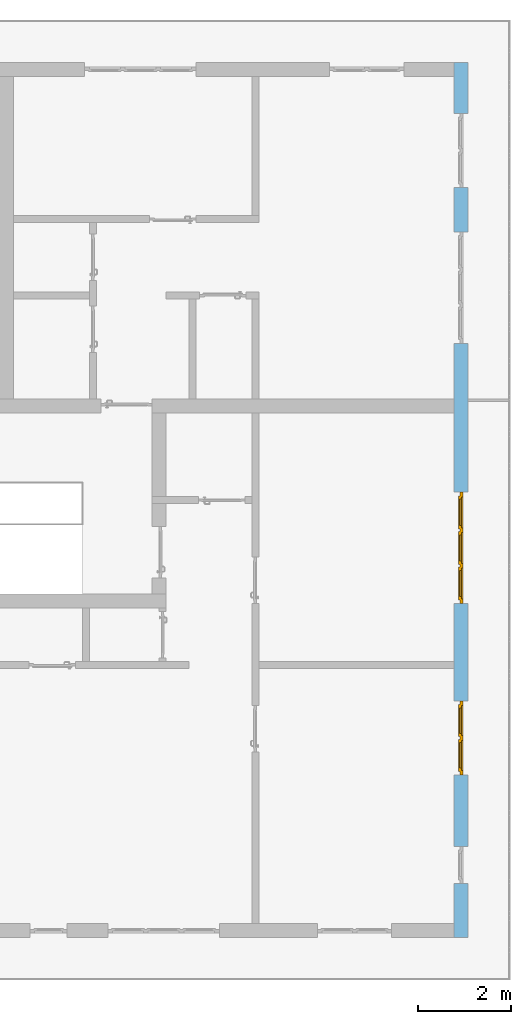
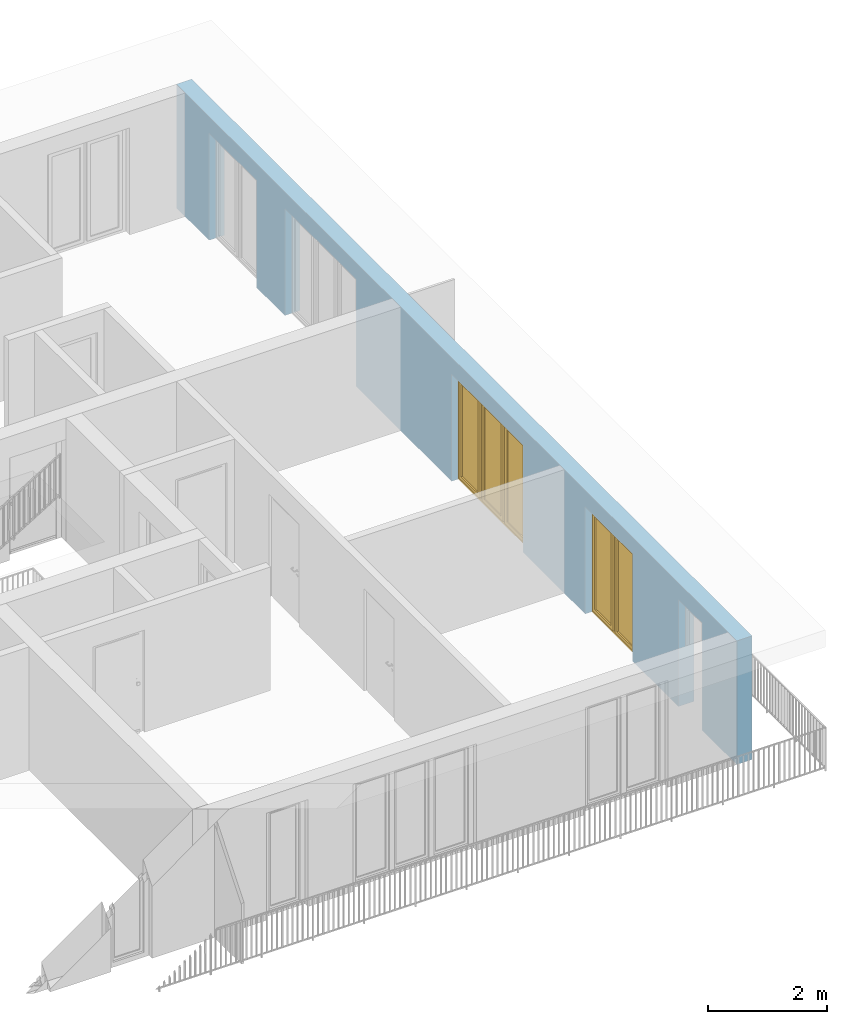
# One storey, part 21 of 54: 2 windows, 5 openings, plus 1 element that does not belong to this part.
"""IFC4 building model written with IfcOpenShell, lengths in metres."""

from ifc_helpers import new_model, entity, si_unit, converted_unit, derived_unit, direction, frame, origin_with_axes, place, context, subcontext, project, spatial, polygons, source, transform, mapped, material, type_object, element, fill, save


model = new_model("IFC4")

# Units and contexts
model_context = context("Model", 3, precision=1e-05, world=origin_with_axes(), true_north=direction((0.0, 1.0)))
body_context = subcontext(model_context, "Body", "Model", "MODEL_VIEW")
ifc_project = project(units=[si_unit("LENGTHUNIT", "METRE"), si_unit("AREAUNIT", "SQUARE_METRE"), si_unit("VOLUMEUNIT", "CUBIC_METRE"), converted_unit("PLANEANGLEUNIT", "DEGREE", entity("IfcPlaneAngleMeasure", 0.0174532925199), si_unit("PLANEANGLEUNIT", "RADIAN"), dimensions=[0, 0, 0, 0, 0, 0, 0]), converted_unit("TIMEUNIT", "Year", entity("IfcTimeMeasure", 31556926.0), si_unit("TIMEUNIT", "SECOND"), dimensions=[0, 0, 1, 0, 0, 0, 0]), si_unit("MASSUNIT", "GRAM", prefix="KILO"), si_unit("THERMODYNAMICTEMPERATUREUNIT", "DEGREE_CELSIUS"), si_unit("LUMINOUSINTENSITYUNIT", "LUMEN"), si_unit("ENERGYUNIT", "JOULE", prefix="MEGA"), derived_unit("THERMALCONDUCTANCEUNIT", [(si_unit("POWERUNIT", "WATT"), 1), (si_unit("LENGTHUNIT", "METRE"), -1), (si_unit("THERMODYNAMICTEMPERATUREUNIT", "KELVIN"), -1)]), derived_unit("SPECIFICHEATCAPACITYUNIT", [(si_unit("ENERGYUNIT", "JOULE"), 1), (si_unit("MASSUNIT", "GRAM", prefix="KILO"), -1), (si_unit("THERMODYNAMICTEMPERATUREUNIT", "KELVIN"), -1)]), derived_unit("MASSDENSITYUNIT", [(si_unit("MASSUNIT", "GRAM", prefix="KILO"), 1), (si_unit("VOLUMEUNIT", "CUBIC_METRE"), -1)])], contexts=[model_context])

# Site, building, storey
site_placement = place(None, origin_with_axes())
site = spatial("IfcSite", under=ifc_project, at=site_placement, CompositionType="ELEMENT")
building_placement = place(site_placement, origin_with_axes())
building = spatial("IfcBuilding", under=site, at=building_placement, CompositionType="ELEMENT")
storey_placement = place(building_placement, frame((0.0, 0.0, 6.29), z_axis=(0.0, 0.0, 1.0), x_axis=(1.0, 0.0, 0.0)))
storey = spatial("IfcBuildingStorey", under=building, at=storey_placement, Name="2. Geschoss", CompositionType="ELEMENT", Elevation=6.29)

# Wall, openings, windows
ifc_material = material()
wall_type = type_object("IfcWallType", Name="300", PredefinedType="NOTDEFINED")
wall_placement = place(storey_placement, frame((9.3378006196, -9.92881223104, 0.0), z_axis=(0.0, 0.0, 1.0), x_axis=(0.0, 1.0, 0.0)))
wall = element("IfcWall", 1, at=wall_placement, inside=storey, type_object=wall_type, material=ifc_material, Name="Wand-001", PredefinedType="NOTDEFINED", context=body_context, shape_type="Tessellation", body=[
    polygons([(1.16441876325, 0.1, 2.2), (1.96441876325, 0.1, 2.2), (1.96441876325, 0.0, 2.2), (1.16441876325, 0.0, 2.2), (1.16441876325, 0.3, 2.2), (1.96441876325, 0.3, 2.2), (1.96441876325, 0.1, 0.0), (1.96441876325, 0.0, 0.0), (18.85, 0.0, 2.54), (0.0, 0.0, 2.54), (0.0, 0.0, 0.0), (1.16441876325, 0.0, 0.0), (3.5, 0.0, 0.0), (3.5, 0.0, 2.2), (5.1, 0.0, 2.2), (5.1, 0.0, 0.0), (7.1921181063, 0.0, 0.0), (7.1921181063, 0.0, 2.2), (9.5921181063, 0.0, 2.2), (9.5921181063, 0.0, 0.0), (12.8, 0.0, 0.0), (12.8, 0.0, 2.2), (15.2, 0.0, 2.2), (15.2, 0.0, 0.0), (16.15, 0.0, 0.0), (16.15, 0.0, 2.2), (17.75, 0.0, 2.2), (17.75, 0.0, 0.0), (18.85, 0.0, 0.0), (1.16441876325, 0.1, 0.0), (1.16441876325, 0.3, 0.0), (0.0, 0.3, 0.0), (0.0, 0.3, 2.54), (18.85, 0.3, 2.54), (18.85, 0.3, 0.0), (17.75, 0.3, 0.0), (17.75, 0.3, 2.2), (16.15, 0.3, 2.2), (16.15, 0.3, 0.0), (15.2, 0.3, 0.0), (15.2, 0.3, 2.2), (12.8, 0.3, 2.2), (12.8, 0.3, 0.0), (9.5921181063, 0.3, 0.0), (9.5921181063, 0.3, 2.2), (7.1921181063, 0.3, 2.2), (7.1921181063, 0.3, 0.0), (5.1, 0.3, 0.0), (5.1, 0.3, 2.2), (3.5, 0.3, 2.2), (3.5, 0.3, 0.0), (1.96441876325, 0.3, 0.0), (3.5, 0.1, 0.0), (3.5, 0.1, 2.2), (5.1, 0.1, 2.2), (5.1, 0.1, 0.0), (7.1921181063, 0.1, 0.0), (7.1921181063, 0.1, 2.2), (9.5921181063, 0.1, 2.2), (9.5921181063, 0.1, 0.0), (12.8, 0.1, 0.0), (12.8, 0.1, 2.2), (15.2, 0.1, 2.2), (15.2, 0.1, 0.0), (16.15, 0.1, 0.0), (16.15, 0.1, 2.2), (17.75, 0.1, 2.2), (17.75, 0.1, 0.0)], [[[1, 2, 3, 4]], [[2, 1, 5, 6]], [[2, 7, 8, 3]], [[9, 10, 11, 12, 4, 3, 8, 13, 14, 15, 16, 17, 18, 19, 20, 21, 22, 23, 24, 25, 26, 27, 28, 29]], [[30, 1, 4, 12]], [[1, 30, 31, 5]], [[5, 31, 32, 33, 34, 35, 36, 37, 38, 39, 40, 41, 42, 43, 44, 45, 46, 47, 48, 49, 50, 51, 52, 6]], [[7, 2, 6, 52]], [[7, 52, 51, 53, 13, 8]], [[9, 34, 33, 10]], [[33, 32, 11, 10]], [[31, 30, 12, 11, 32]], [[14, 13, 53, 54]], [[15, 14, 54, 55]], [[16, 15, 55, 56]], [[56, 48, 47, 57, 17, 16]], [[57, 58, 18, 17]], [[58, 59, 19, 18]], [[59, 60, 20, 19]], [[60, 44, 43, 61, 21, 20]], [[22, 21, 61, 62]], [[23, 22, 62, 63]], [[24, 23, 63, 64]], [[64, 40, 39, 65, 25, 24]], [[65, 66, 26, 25]], [[66, 67, 27, 26]], [[67, 68, 28, 27]], [[36, 35, 29, 28, 68]], [[9, 29, 35, 34]], [[68, 67, 37, 36]], [[67, 66, 38, 37]], [[66, 65, 39, 38]], [[41, 40, 64, 63]], [[42, 41, 63, 62]], [[43, 42, 62, 61]], [[60, 59, 45, 44]], [[59, 58, 46, 45]], [[58, 57, 47, 46]], [[49, 48, 56, 55]], [[50, 49, 55, 54]], [[51, 50, 54, 53]]], closed=True),
])
opening_1_placement = place(wall_placement, frame((16.95, 0.0, 0.0), z_axis=(0.0, 0.0, 1.0), x_axis=(1.0, 0.0, 0.0)))
element("IfcOpeningElement", 2, at=opening_1_placement, cuts=wall, Name="Fenster-001", context=body_context, identifier="Reference", shape_type="Tessellation", body=[
    polygons([(0.8, 0.1, 0.0), (0.8, 0.1, 2.2), (0.8, -0.000999999999999, 2.2), (0.8, -0.000999999999999, 0.0), (0.8, 0.301, 0.0), (0.8, 0.301, 2.2), (-0.8, 0.1, 2.2), (-0.8, -0.000999999999999, 2.2), (-0.8, 0.301, 2.2), (-0.8, -0.000999999999999, 0.0), (-0.8, 0.1, 0.0), (-0.8, 0.301, 0.0)], [[[1, 2, 3, 4]], [[2, 1, 5, 6]], [[7, 8, 3, 2, 6, 9]], [[8, 10, 4, 3]], [[1, 4, 10, 11, 12, 5]], [[6, 5, 12, 9]], [[7, 11, 10, 8]], [[11, 7, 9, 12]]], closed=True),
])
opening_2_placement = place(wall_placement, frame((14.0, 0.0, 0.0), z_axis=(0.0, 0.0, 1.0), x_axis=(1.0, 0.0, 0.0)))
element("IfcOpeningElement", 3, at=opening_2_placement, cuts=wall, Name="Fenster-002", context=body_context, identifier="Reference", shape_type="Tessellation", body=[
    polygons([(1.2, 0.1, 0.0), (1.2, 0.1, 2.2), (1.2, -0.000999999999999, 2.2), (1.2, -0.000999999999999, 0.0), (1.2, 0.301, 0.0), (1.2, 0.301, 2.2), (-1.2, 0.1, 2.2), (-1.2, -0.000999999999999, 2.2), (-1.2, 0.301, 2.2), (-1.2, -0.000999999999999, 0.0), (-1.2, 0.1, 0.0), (-1.2, 0.301, 0.0)], [[[1, 2, 3, 4]], [[2, 1, 5, 6]], [[7, 8, 3, 2, 6, 9]], [[8, 10, 4, 3]], [[1, 4, 10, 11, 12, 5]], [[6, 5, 12, 9]], [[7, 11, 10, 8]], [[11, 7, 9, 12]]], closed=True),
])
opening_3_placement = place(wall_placement, frame((8.3921181063, 0.0, 0.0), z_axis=(0.0, 0.0, 1.0), x_axis=(1.0, 0.0, 0.0)))
opening_3 = element("IfcOpeningElement", 4, at=opening_3_placement, cuts=wall, Name="Fenster-002", context=body_context, identifier="Reference", shape_type="Tessellation", body=[
    polygons([(1.2, 0.1, 0.0), (1.2, 0.1, 2.2), (1.2, -0.000999999999999, 2.2), (1.2, -0.000999999999999, 0.0), (1.2, 0.301, 0.0), (1.2, 0.301, 2.2), (-1.2, 0.1, 2.2), (-1.2, -0.000999999999999, 2.2), (-1.2, 0.301, 2.2), (-1.2, -0.000999999999999, 0.0), (-1.2, 0.1, 0.0), (-1.2, 0.301, 0.0)], [[[1, 2, 3, 4]], [[2, 1, 5, 6]], [[7, 8, 3, 2, 6, 9]], [[8, 10, 4, 3]], [[1, 4, 10, 11, 12, 5]], [[6, 5, 12, 9]], [[7, 11, 10, 8]], [[11, 7, 9, 12]]], closed=True),
])
opening_4_placement = place(wall_placement, frame((4.3, 0.0, 0.0), z_axis=(0.0, 0.0, 1.0), x_axis=(1.0, 0.0, 0.0)))
opening_4 = element("IfcOpeningElement", 5, at=opening_4_placement, cuts=wall, Name="Fenster-001", context=body_context, identifier="Reference", shape_type="Tessellation", body=[
    polygons([(0.8, 0.1, 0.0), (0.8, 0.1, 2.2), (0.8, -0.000999999999999, 2.2), (0.8, -0.000999999999999, 0.0), (0.8, 0.301, 0.0), (0.8, 0.301, 2.2), (-0.8, 0.1, 2.2), (-0.8, -0.000999999999999, 2.2), (-0.8, 0.301, 2.2), (-0.8, -0.000999999999999, 0.0), (-0.8, 0.1, 0.0), (-0.8, 0.301, 0.0)], [[[1, 2, 3, 4]], [[2, 1, 5, 6]], [[7, 8, 3, 2, 6, 9]], [[8, 10, 4, 3]], [[1, 4, 10, 11, 12, 5]], [[6, 5, 12, 9]], [[7, 11, 10, 8]], [[11, 7, 9, 12]]], closed=True),
])
opening_5_placement = place(wall_placement, frame((1.56441876325, 0.0, 0.0), z_axis=(0.0, 0.0, 1.0), x_axis=(1.0, 0.0, 0.0)))
element("IfcOpeningElement", 6, at=opening_5_placement, cuts=wall, Name="Fenster-003", context=body_context, identifier="Reference", shape_type="Tessellation", body=[
    polygons([(0.4, 0.1, 0.0), (0.4, 0.1, 2.2), (0.4, -0.000999999999999, 2.2), (0.4, -0.000999999999999, 0.0), (0.4, 0.301, 0.0), (0.4, 0.301, 2.2), (-0.4, 0.1, 2.2), (-0.4, -0.000999999999999, 2.2), (-0.4, 0.301, 2.2), (-0.4, -0.000999999999999, 0.0), (-0.4, 0.1, 0.0), (-0.4, 0.301, 0.0)], [[[1, 2, 3, 4]], [[2, 1, 5, 6]], [[7, 8, 3, 2, 6, 9]], [[8, 10, 4, 3]], [[1, 4, 10, 11, 12, 5]], [[6, 5, 12, 9]], [[7, 11, 10, 8]], [[11, 7, 9, 12]]], closed=True),
])
window_type_1 = type_object("IfcWindowType", Name="3-1+1+1 26", PartitioningType="TRIPLE_PANEL_VERTICAL", PredefinedType="WINDOW")
shared_shape_1 = source(origin_with_axes(), body_context, "Body", "Tessellation", [
    polygons([(-1.2, -0.07, 0.0), (-1.2, 0.0, 0.0), (-1.1, 0.0, 0.1), (-1.1, -0.07, 0.1), (-1.2, -0.07, 2.2), (-1.2, 0.0, 2.2), (-1.1, 0.0, 2.1), (-1.1, -0.07, 2.1)], [[[1, 2, 3, 4]], [[5, 6, 2, 1]], [[2, 6, 7, 3]], [[4, 3, 7, 8]], [[1, 4, 8, 5]], [[8, 7, 6, 5]]], closed=True),
    polygons([(1.2, -0.07, 0.0), (1.2, 0.0, 0.0), (1.2, 0.0, 2.2), (1.2, -0.07, 2.2), (1.1, -0.07, 0.1), (1.1, 0.0, 0.1), (1.1, 0.0, 2.1), (1.1, -0.07, 2.1)], [[[1, 2, 3, 4]], [[5, 6, 2, 1]], [[2, 6, 7, 3]], [[4, 3, 7, 8]], [[1, 4, 8, 5]], [[8, 7, 6, 5]]], closed=True),
    polygons([(-1.2, -0.07, 0.0), (-1.2, 0.0, 0.0), (1.2, 0.0, 0.0), (1.2, -0.07, 0.0), (-1.1, -0.07, 0.1), (-1.1, 0.0, 0.1), (-0.433333333333, 0.0, 0.1), (-0.333333333333, 0.0, 0.1), (0.333333333333, 0.0, 0.1), (0.433333333333, 0.0, 0.1), (1.1, 0.0, 0.1), (1.1, -0.07, 0.1), (0.433333333333, -0.07, 0.1), (0.333333333333, -0.07, 0.1), (-0.333333333333, -0.07, 0.1), (-0.433333333333, -0.07, 0.1)], [[[1, 2, 3, 4]], [[5, 6, 2, 1]], [[2, 6, 7, 8, 9, 10, 11, 3]], [[4, 3, 11, 12]], [[1, 4, 12, 13, 14, 15, 16, 5]], [[16, 7, 6, 5]], [[15, 8, 7, 16]], [[14, 9, 8, 15]], [[13, 10, 9, 14]], [[12, 11, 10, 13]]], closed=True),
    polygons([(-1.2, -0.07, 2.2), (-1.2, 0.0, 2.2), (-1.1, 0.0, 2.1), (-1.1, -0.07, 2.1), (1.2, -0.07, 2.2), (1.2, 0.0, 2.2), (1.1, 0.0, 2.1), (0.433333333333, 0.0, 2.1), (0.333333333333, 0.0, 2.1), (-0.333333333333, 0.0, 2.1), (-0.433333333333, 0.0, 2.1), (-0.433333333333, -0.07, 2.1), (-0.333333333333, -0.07, 2.1), (0.333333333333, -0.07, 2.1), (0.433333333333, -0.07, 2.1), (1.1, -0.07, 2.1)], [[[1, 2, 3, 4]], [[5, 6, 2, 1]], [[2, 6, 7, 8, 9, 10, 11, 3]], [[4, 3, 11, 12]], [[1, 4, 12, 13, 14, 15, 16, 5]], [[16, 7, 6, 5]], [[15, 8, 7, 16]], [[14, 9, 8, 15]], [[13, 10, 9, 14]], [[12, 11, 10, 13]]], closed=True),
    polygons([(0.333333333333, -0.07, 0.1), (0.333333333333, 0.0, 0.1), (0.433333333333, 0.0, 0.1), (0.433333333333, -0.07, 0.1), (0.333333333333, -0.07, 2.1), (0.333333333333, 0.0, 2.1), (0.433333333333, 0.0, 2.1), (0.433333333333, -0.07, 2.1)], [[[1, 2, 3, 4]], [[5, 6, 2, 1]], [[2, 6, 7, 3]], [[4, 3, 7, 8]], [[1, 4, 8, 5]], [[8, 7, 6, 5]]], closed=True),
    polygons([(-0.433333333333, -0.07, 0.1), (-0.433333333333, 0.0, 0.1), (-0.333333333333, 0.0, 0.1), (-0.333333333333, -0.07, 0.1), (-0.433333333333, -0.07, 2.1), (-0.433333333333, 0.0, 2.1), (-0.333333333333, 0.0, 2.1), (-0.333333333333, -0.07, 2.1)], [[[1, 2, 3, 4]], [[5, 6, 2, 1]], [[2, 6, 7, 3]], [[4, 3, 7, 8]], [[1, 4, 8, 5]], [[8, 7, 6, 5]]], closed=True),
    polygons([(-1.12, 0.0, 0.08), (-1.12, 0.03, 0.08), (-1.05, 0.03, 0.15), (-1.05, 0.0, 0.15), (-1.12, 0.0, 2.12), (-1.12, 0.03, 2.12), (-1.05, 0.03, 2.05), (-1.05, 0.0, 2.05)], [[[1, 2, 3, 4]], [[5, 6, 2, 1]], [[2, 6, 7, 3]], [[4, 3, 7, 8]], [[1, 4, 8, 5]], [[8, 7, 6, 5]]], closed=True),
    polygons([(-0.413333333333, 0.0, 0.08), (-0.483333333333, 0.0, 0.15), (-0.483333333333, 0.03, 0.15), (-0.413333333333, 0.03, 0.08), (-0.413333333333, 0.0, 2.12), (-0.483333333333, 0.0, 2.05), (-0.483333333333, 0.03, 2.05), (-0.413333333333, 0.03, 2.12)], [[[1, 2, 3, 4]], [[1, 5, 6, 2]], [[2, 6, 7, 3]], [[4, 3, 7, 8]], [[5, 1, 4, 8]], [[6, 5, 8, 7]]], closed=True),
    polygons([(-1.12, 0.0, 0.08), (-1.12, 0.03, 0.08), (-0.413333333333, 0.03, 0.08), (-0.413333333333, 0.0, 0.08), (-1.05, 0.0, 0.15), (-1.05, 0.03, 0.15), (-0.483333333333, 0.03, 0.15), (-0.483333333333, 0.0, 0.15)], [[[1, 2, 3, 4]], [[5, 6, 2, 1]], [[2, 6, 7, 3]], [[4, 3, 7, 8]], [[1, 4, 8, 5]], [[8, 7, 6, 5]]], closed=True),
    polygons([(-1.12, 0.0, 2.12), (-0.413333333333, 0.0, 2.12), (-0.413333333333, 0.03, 2.12), (-1.12, 0.03, 2.12), (-1.05, 0.0, 2.05), (-0.483333333333, 0.0, 2.05), (-0.483333333333, 0.03, 2.05), (-1.05, 0.03, 2.05)], [[[1, 2, 3, 4]], [[1, 5, 6, 2]], [[2, 6, 7, 3]], [[4, 3, 7, 8]], [[5, 1, 4, 8]], [[6, 5, 8, 7]]], closed=True),
    polygons([(-1.1, -0.03, 0.1), (-1.1, 0.0, 0.1), (-1.05, 0.0, 0.15), (-1.05, -0.03, 0.15), (-1.1, -0.03, 2.1), (-1.1, 0.0, 2.1), (-1.05, 0.0, 2.05), (-1.05, -0.03, 2.05)], [[[1, 2, 3, 4]], [[5, 6, 2, 1]], [[2, 6, 7, 3]], [[4, 3, 7, 8]], [[1, 4, 8, 5]], [[8, 7, 6, 5]]], closed=True),
    polygons([(-0.433333333333, -0.03, 0.1), (-0.483333333333, -0.03, 0.15), (-0.483333333333, 0.0, 0.15), (-0.433333333333, 0.0, 0.1), (-0.433333333333, -0.03, 2.1), (-0.483333333333, -0.03, 2.05), (-0.483333333333, 0.0, 2.05), (-0.433333333333, 0.0, 2.1)], [[[1, 2, 3, 4]], [[1, 5, 6, 2]], [[2, 6, 7, 3]], [[4, 3, 7, 8]], [[5, 1, 4, 8]], [[6, 5, 8, 7]]], closed=True),
    polygons([(-1.1, -0.03, 0.1), (-1.1, 0.0, 0.1), (-0.433333333333, 0.0, 0.1), (-0.433333333333, -0.03, 0.1), (-1.05, -0.03, 0.15), (-1.05, 0.0, 0.15), (-0.483333333333, 0.0, 0.15), (-0.483333333333, -0.03, 0.15)], [[[1, 2, 3, 4]], [[5, 6, 2, 1]], [[2, 6, 7, 3]], [[4, 3, 7, 8]], [[1, 4, 8, 5]], [[8, 7, 6, 5]]], closed=True),
    polygons([(-1.1, -0.03, 2.1), (-0.433333333333, -0.03, 2.1), (-0.433333333333, 0.0, 2.1), (-1.1, 0.0, 2.1), (-1.05, -0.03, 2.05), (-0.483333333333, -0.03, 2.05), (-0.483333333333, 0.0, 2.05), (-1.05, 0.0, 2.05)], [[[1, 2, 3, 4]], [[1, 5, 6, 2]], [[2, 6, 7, 3]], [[4, 3, 7, 8]], [[5, 1, 4, 8]], [[6, 5, 8, 7]]], closed=True),
    polygons([(-1.05, -0.005, 0.15), (-1.05, 0.005, 0.15), (-0.483333333333, 0.005, 0.15), (-0.483333333333, -0.005, 0.15), (-1.05, -0.005, 2.05), (-1.05, 0.005, 2.05), (-0.483333333333, 0.005, 2.05), (-0.483333333333, -0.005, 2.05)], [[[1, 2, 3, 4]], [[5, 6, 2, 1]], [[2, 6, 7, 3]], [[4, 3, 7, 8]], [[1, 4, 8, 5]], [[8, 7, 6, 5]]], closed=True),
    polygons([(-0.353333333333, 0.0, 0.08), (-0.353333333333, 0.03, 0.08), (-0.283333333333, 0.03, 0.15), (-0.283333333333, 0.0, 0.15), (-0.353333333333, 0.0, 2.12), (-0.353333333333, 0.03, 2.12), (-0.283333333333, 0.03, 2.05), (-0.283333333333, 0.0, 2.05)], [[[1, 2, 3, 4]], [[5, 6, 2, 1]], [[2, 6, 7, 3]], [[4, 3, 7, 8]], [[1, 4, 8, 5]], [[8, 7, 6, 5]]], closed=True),
    polygons([(0.353333333333, 0.0, 0.08), (0.283333333333, 0.0, 0.15), (0.283333333333, 0.03, 0.15), (0.353333333333, 0.03, 0.08), (0.353333333333, 0.0, 2.12), (0.283333333333, 0.0, 2.05), (0.283333333333, 0.03, 2.05), (0.353333333333, 0.03, 2.12)], [[[1, 2, 3, 4]], [[1, 5, 6, 2]], [[2, 6, 7, 3]], [[4, 3, 7, 8]], [[5, 1, 4, 8]], [[6, 5, 8, 7]]], closed=True),
    polygons([(-0.353333333333, 0.0, 0.08), (-0.353333333333, 0.03, 0.08), (0.353333333333, 0.03, 0.08), (0.353333333333, 0.0, 0.08), (-0.283333333333, 0.0, 0.15), (-0.283333333333, 0.03, 0.15), (0.283333333333, 0.03, 0.15), (0.283333333333, 0.0, 0.15)], [[[1, 2, 3, 4]], [[5, 6, 2, 1]], [[2, 6, 7, 3]], [[4, 3, 7, 8]], [[1, 4, 8, 5]], [[8, 7, 6, 5]]], closed=True),
    polygons([(-0.353333333333, 0.0, 2.12), (0.353333333333, 0.0, 2.12), (0.353333333333, 0.03, 2.12), (-0.353333333333, 0.03, 2.12), (-0.283333333333, 0.0, 2.05), (0.283333333333, 0.0, 2.05), (0.283333333333, 0.03, 2.05), (-0.283333333333, 0.03, 2.05)], [[[1, 2, 3, 4]], [[1, 5, 6, 2]], [[2, 6, 7, 3]], [[4, 3, 7, 8]], [[5, 1, 4, 8]], [[6, 5, 8, 7]]], closed=True),
    polygons([(-0.333333333333, -0.03, 0.1), (-0.333333333333, 0.0, 0.1), (-0.283333333333, 0.0, 0.15), (-0.283333333333, -0.03, 0.15), (-0.333333333333, -0.03, 2.1), (-0.333333333333, 0.0, 2.1), (-0.283333333333, 0.0, 2.05), (-0.283333333333, -0.03, 2.05)], [[[1, 2, 3, 4]], [[5, 6, 2, 1]], [[2, 6, 7, 3]], [[4, 3, 7, 8]], [[1, 4, 8, 5]], [[8, 7, 6, 5]]], closed=True),
    polygons([(0.333333333333, -0.03, 0.1), (0.283333333333, -0.03, 0.15), (0.283333333333, 0.0, 0.15), (0.333333333333, 0.0, 0.1), (0.333333333333, -0.03, 2.1), (0.283333333333, -0.03, 2.05), (0.283333333333, 0.0, 2.05), (0.333333333333, 0.0, 2.1)], [[[1, 2, 3, 4]], [[1, 5, 6, 2]], [[2, 6, 7, 3]], [[4, 3, 7, 8]], [[5, 1, 4, 8]], [[6, 5, 8, 7]]], closed=True),
    polygons([(-0.333333333333, -0.03, 0.1), (-0.333333333333, 0.0, 0.1), (0.333333333333, 0.0, 0.1), (0.333333333333, -0.03, 0.1), (-0.283333333333, -0.03, 0.15), (-0.283333333333, 0.0, 0.15), (0.283333333333, 0.0, 0.15), (0.283333333333, -0.03, 0.15)], [[[1, 2, 3, 4]], [[5, 6, 2, 1]], [[2, 6, 7, 3]], [[4, 3, 7, 8]], [[1, 4, 8, 5]], [[8, 7, 6, 5]]], closed=True),
    polygons([(-0.333333333333, -0.03, 2.1), (0.333333333333, -0.03, 2.1), (0.333333333333, 0.0, 2.1), (-0.333333333333, 0.0, 2.1), (-0.283333333333, -0.03, 2.05), (0.283333333333, -0.03, 2.05), (0.283333333333, 0.0, 2.05), (-0.283333333333, 0.0, 2.05)], [[[1, 2, 3, 4]], [[1, 5, 6, 2]], [[2, 6, 7, 3]], [[4, 3, 7, 8]], [[5, 1, 4, 8]], [[6, 5, 8, 7]]], closed=True),
    polygons([(-0.283333333333, -0.005, 0.15), (-0.283333333333, 0.005, 0.15), (0.283333333333, 0.005, 0.15), (0.283333333333, -0.005, 0.15), (-0.283333333333, -0.005, 2.05), (-0.283333333333, 0.005, 2.05), (0.283333333333, 0.005, 2.05), (0.283333333333, -0.005, 2.05)], [[[1, 2, 3, 4]], [[5, 6, 2, 1]], [[2, 6, 7, 3]], [[4, 3, 7, 8]], [[1, 4, 8, 5]], [[8, 7, 6, 5]]], closed=True),
    polygons([(0.413333333333, 0.0, 0.08), (0.413333333333, 0.03, 0.08), (0.483333333333, 0.03, 0.15), (0.483333333333, 0.0, 0.15), (0.413333333333, 0.0, 2.12), (0.413333333333, 0.03, 2.12), (0.483333333333, 0.03, 2.05), (0.483333333333, 0.0, 2.05)], [[[1, 2, 3, 4]], [[5, 6, 2, 1]], [[2, 6, 7, 3]], [[4, 3, 7, 8]], [[1, 4, 8, 5]], [[8, 7, 6, 5]]], closed=True),
    polygons([(1.12, 0.0, 0.08), (1.05, 0.0, 0.15), (1.05, 0.03, 0.15), (1.12, 0.03, 0.08), (1.12, 0.0, 2.12), (1.05, 0.0, 2.05), (1.05, 0.03, 2.05), (1.12, 0.03, 2.12)], [[[1, 2, 3, 4]], [[1, 5, 6, 2]], [[2, 6, 7, 3]], [[4, 3, 7, 8]], [[5, 1, 4, 8]], [[6, 5, 8, 7]]], closed=True),
    polygons([(0.413333333333, 0.0, 0.08), (0.413333333333, 0.03, 0.08), (1.12, 0.03, 0.08), (1.12, 0.0, 0.08), (0.483333333333, 0.0, 0.15), (0.483333333333, 0.03, 0.15), (1.05, 0.03, 0.15), (1.05, 0.0, 0.15)], [[[1, 2, 3, 4]], [[5, 6, 2, 1]], [[2, 6, 7, 3]], [[4, 3, 7, 8]], [[1, 4, 8, 5]], [[8, 7, 6, 5]]], closed=True),
    polygons([(0.413333333333, 0.0, 2.12), (1.12, 0.0, 2.12), (1.12, 0.03, 2.12), (0.413333333333, 0.03, 2.12), (0.483333333333, 0.0, 2.05), (1.05, 0.0, 2.05), (1.05, 0.03, 2.05), (0.483333333333, 0.03, 2.05)], [[[1, 2, 3, 4]], [[1, 5, 6, 2]], [[2, 6, 7, 3]], [[4, 3, 7, 8]], [[5, 1, 4, 8]], [[6, 5, 8, 7]]], closed=True),
    polygons([(0.433333333333, -0.03, 0.1), (0.433333333333, 0.0, 0.1), (0.483333333333, 0.0, 0.15), (0.483333333333, -0.03, 0.15), (0.433333333333, -0.03, 2.1), (0.433333333333, 0.0, 2.1), (0.483333333333, 0.0, 2.05), (0.483333333333, -0.03, 2.05)], [[[1, 2, 3, 4]], [[5, 6, 2, 1]], [[2, 6, 7, 3]], [[4, 3, 7, 8]], [[1, 4, 8, 5]], [[8, 7, 6, 5]]], closed=True),
    polygons([(1.1, -0.03, 0.1), (1.05, -0.03, 0.15), (1.05, 0.0, 0.15), (1.1, 0.0, 0.1), (1.1, -0.03, 2.1), (1.05, -0.03, 2.05), (1.05, 0.0, 2.05), (1.1, 0.0, 2.1)], [[[1, 2, 3, 4]], [[1, 5, 6, 2]], [[2, 6, 7, 3]], [[4, 3, 7, 8]], [[5, 1, 4, 8]], [[6, 5, 8, 7]]], closed=True),
    polygons([(0.433333333333, -0.03, 0.1), (0.433333333333, 0.0, 0.1), (1.1, 0.0, 0.1), (1.1, -0.03, 0.1), (0.483333333333, -0.03, 0.15), (0.483333333333, 0.0, 0.15), (1.05, 0.0, 0.15), (1.05, -0.03, 0.15)], [[[1, 2, 3, 4]], [[5, 6, 2, 1]], [[2, 6, 7, 3]], [[4, 3, 7, 8]], [[1, 4, 8, 5]], [[8, 7, 6, 5]]], closed=True),
    polygons([(0.433333333333, -0.03, 2.1), (1.1, -0.03, 2.1), (1.1, 0.0, 2.1), (0.433333333333, 0.0, 2.1), (0.483333333333, -0.03, 2.05), (1.05, -0.03, 2.05), (1.05, 0.0, 2.05), (0.483333333333, 0.0, 2.05)], [[[1, 2, 3, 4]], [[1, 5, 6, 2]], [[2, 6, 7, 3]], [[4, 3, 7, 8]], [[5, 1, 4, 8]], [[6, 5, 8, 7]]], closed=True),
    polygons([(0.483333333333, -0.005, 0.15), (0.483333333333, 0.005, 0.15), (1.05, 0.005, 0.15), (1.05, -0.005, 0.15), (0.483333333333, -0.005, 2.05), (0.483333333333, 0.005, 2.05), (1.05, 0.005, 2.05), (1.05, -0.005, 2.05)], [[[1, 2, 3, 4]], [[5, 6, 2, 1]], [[2, 6, 7, 3]], [[4, 3, 7, 8]], [[1, 4, 8, 5]], [[8, 7, 6, 5]]], closed=True),
])
window_1_placement = place(opening_3_placement, frame((-1.2, 0.0, 0.0), z_axis=(0.0, 0.0, 1.0), x_axis=(1.0, 0.0, 0.0)))
window_1 = element("IfcWindow", 7, at=window_1_placement, inside=storey, type_object=window_type_1, Name="Fenster-002", OverallHeight=2.2, OverallWidth=2.4, PredefinedType="WINDOW", context=body_context, shape_type="MappedRepresentation", body=[
    mapped(shared_shape_1, transform((1.2, 0.17, 0.0))),
])
fill(opening_3, window_1)
window_type_2 = type_object("IfcWindowType", Name="2-1+1 26", PartitioningType="DOUBLE_PANEL_VERTICAL", PredefinedType="WINDOW")
shared_shape_2 = source(origin_with_axes(), body_context, "Body", "Tessellation", [
    polygons([(0.8, -0.07, 0.0), (0.7, -0.07, 0.1), (0.7, 0.0, 0.1), (0.8, 0.0, 0.0), (0.8, -0.07, 2.2), (0.7, -0.07, 2.1), (0.7, 0.0, 2.1), (0.8, 0.0, 2.2)], [[[1, 2, 3, 4]], [[1, 5, 6, 2]], [[2, 6, 7, 3]], [[4, 3, 7, 8]], [[5, 1, 4, 8]], [[6, 5, 8, 7]]], closed=True),
    polygons([(-0.8, -0.07, 0.0), (-0.8, -0.07, 2.2), (-0.8, 0.0, 2.2), (-0.8, 0.0, 0.0), (-0.7, -0.07, 0.1), (-0.7, -0.07, 2.1), (-0.7, 0.0, 2.1), (-0.7, 0.0, 0.1)], [[[1, 2, 3, 4]], [[1, 5, 6, 2]], [[2, 6, 7, 3]], [[4, 3, 7, 8]], [[5, 1, 4, 8]], [[6, 5, 8, 7]]], closed=True),
    polygons([(0.8, -0.07, 0.0), (-0.8, -0.07, 0.0), (-0.8, 0.0, 0.0), (0.8, 0.0, 0.0), (0.7, -0.07, 0.1), (0.05, -0.07, 0.1), (-0.05, -0.07, 0.1), (-0.7, -0.07, 0.1), (-0.7, 0.0, 0.1), (-0.05, 0.0, 0.1), (0.05, 0.0, 0.1), (0.7, 0.0, 0.1)], [[[1, 2, 3, 4]], [[1, 5, 6, 7, 8, 2]], [[2, 8, 9, 3]], [[4, 3, 9, 10, 11, 12]], [[5, 1, 4, 12]], [[6, 5, 12, 11]], [[7, 6, 11, 10]], [[8, 7, 10, 9]]], closed=True),
    polygons([(0.8, -0.07, 2.2), (0.7, -0.07, 2.1), (0.7, 0.0, 2.1), (0.8, 0.0, 2.2), (-0.8, -0.07, 2.2), (-0.7, -0.07, 2.1), (-0.05, -0.07, 2.1), (0.05, -0.07, 2.1), (0.05, 0.0, 2.1), (-0.05, 0.0, 2.1), (-0.7, 0.0, 2.1), (-0.8, 0.0, 2.2)], [[[1, 2, 3, 4]], [[1, 5, 6, 7, 8, 2]], [[2, 8, 9, 3]], [[4, 3, 9, 10, 11, 12]], [[5, 1, 4, 12]], [[6, 5, 12, 11]], [[7, 6, 11, 10]], [[8, 7, 10, 9]]], closed=True),
    polygons([(0.05, -0.07, 0.1), (-0.05, -0.07, 0.1), (-0.05, 0.0, 0.1), (0.05, 0.0, 0.1), (0.05, -0.07, 2.1), (-0.05, -0.07, 2.1), (-0.05, 0.0, 2.1), (0.05, 0.0, 2.1)], [[[1, 2, 3, 4]], [[1, 5, 6, 2]], [[2, 6, 7, 3]], [[4, 3, 7, 8]], [[5, 1, 4, 8]], [[6, 5, 8, 7]]], closed=True),
    polygons([(0.72, 0.0, 0.08), (0.65, 0.0, 0.15), (0.65, 0.03, 0.15), (0.72, 0.03, 0.08), (0.72, 0.0, 2.12), (0.65, 0.0, 2.05), (0.65, 0.03, 2.05), (0.72, 0.03, 2.12)], [[[1, 2, 3, 4]], [[1, 5, 6, 2]], [[2, 6, 7, 3]], [[4, 3, 7, 8]], [[5, 1, 4, 8]], [[6, 5, 8, 7]]], closed=True),
    polygons([(0.03, 0.0, 0.08), (0.03, 0.03, 0.08), (0.1, 0.03, 0.15), (0.1, 0.0, 0.15), (0.03, 0.0, 2.12), (0.03, 0.03, 2.12), (0.1, 0.03, 2.05), (0.1, 0.0, 2.05)], [[[1, 2, 3, 4]], [[5, 6, 2, 1]], [[2, 6, 7, 3]], [[4, 3, 7, 8]], [[1, 4, 8, 5]], [[8, 7, 6, 5]]], closed=True),
    polygons([(0.72, 0.0, 0.08), (0.03, 0.0, 0.08), (0.03, 0.03, 0.08), (0.72, 0.03, 0.08), (0.65, 0.0, 0.15), (0.1, 0.0, 0.15), (0.1, 0.03, 0.15), (0.65, 0.03, 0.15)], [[[1, 2, 3, 4]], [[1, 5, 6, 2]], [[2, 6, 7, 3]], [[4, 3, 7, 8]], [[5, 1, 4, 8]], [[6, 5, 8, 7]]], closed=True),
    polygons([(0.72, 0.0, 2.12), (0.72, 0.03, 2.12), (0.03, 0.03, 2.12), (0.03, 0.0, 2.12), (0.65, 0.0, 2.05), (0.65, 0.03, 2.05), (0.1, 0.03, 2.05), (0.1, 0.0, 2.05)], [[[1, 2, 3, 4]], [[5, 6, 2, 1]], [[2, 6, 7, 3]], [[4, 3, 7, 8]], [[1, 4, 8, 5]], [[8, 7, 6, 5]]], closed=True),
    polygons([(0.7, -0.03, 0.1), (0.65, -0.03, 0.15), (0.65, 0.0, 0.15), (0.7, 0.0, 0.1), (0.7, -0.03, 2.1), (0.65, -0.03, 2.05), (0.65, 0.0, 2.05), (0.7, 0.0, 2.1)], [[[1, 2, 3, 4]], [[1, 5, 6, 2]], [[2, 6, 7, 3]], [[4, 3, 7, 8]], [[5, 1, 4, 8]], [[6, 5, 8, 7]]], closed=True),
    polygons([(0.05, -0.03, 0.1), (0.05, 0.0, 0.1), (0.1, 0.0, 0.15), (0.1, -0.03, 0.15), (0.05, -0.03, 2.1), (0.05, 0.0, 2.1), (0.1, 0.0, 2.05), (0.1, -0.03, 2.05)], [[[1, 2, 3, 4]], [[5, 6, 2, 1]], [[2, 6, 7, 3]], [[4, 3, 7, 8]], [[1, 4, 8, 5]], [[8, 7, 6, 5]]], closed=True),
    polygons([(0.7, -0.03, 0.1), (0.05, -0.03, 0.1), (0.05, 0.0, 0.1), (0.7, 0.0, 0.1), (0.65, -0.03, 0.15), (0.1, -0.03, 0.15), (0.1, 0.0, 0.15), (0.65, 0.0, 0.15)], [[[1, 2, 3, 4]], [[1, 5, 6, 2]], [[2, 6, 7, 3]], [[4, 3, 7, 8]], [[5, 1, 4, 8]], [[6, 5, 8, 7]]], closed=True),
    polygons([(0.7, -0.03, 2.1), (0.7, 0.0, 2.1), (0.05, 0.0, 2.1), (0.05, -0.03, 2.1), (0.65, -0.03, 2.05), (0.65, 0.0, 2.05), (0.1, 0.0, 2.05), (0.1, -0.03, 2.05)], [[[1, 2, 3, 4]], [[5, 6, 2, 1]], [[2, 6, 7, 3]], [[4, 3, 7, 8]], [[1, 4, 8, 5]], [[8, 7, 6, 5]]], closed=True),
    polygons([(0.65, -0.005, 0.15), (0.1, -0.005, 0.15), (0.1, 0.005, 0.15), (0.65, 0.005, 0.15), (0.65, -0.005, 2.05), (0.1, -0.005, 2.05), (0.1, 0.005, 2.05), (0.65, 0.005, 2.05)], [[[1, 2, 3, 4]], [[1, 5, 6, 2]], [[2, 6, 7, 3]], [[4, 3, 7, 8]], [[5, 1, 4, 8]], [[6, 5, 8, 7]]], closed=True),
    polygons([(-0.03, 0.0, 0.08), (-0.1, 0.0, 0.15), (-0.1, 0.03, 0.15), (-0.03, 0.03, 0.08), (-0.03, 0.0, 2.12), (-0.1, 0.0, 2.05), (-0.1, 0.03, 2.05), (-0.03, 0.03, 2.12)], [[[1, 2, 3, 4]], [[1, 5, 6, 2]], [[2, 6, 7, 3]], [[4, 3, 7, 8]], [[5, 1, 4, 8]], [[6, 5, 8, 7]]], closed=True),
    polygons([(-0.72, 0.0, 0.08), (-0.72, 0.03, 0.08), (-0.65, 0.03, 0.15), (-0.65, 0.0, 0.15), (-0.72, 0.0, 2.12), (-0.72, 0.03, 2.12), (-0.65, 0.03, 2.05), (-0.65, 0.0, 2.05)], [[[1, 2, 3, 4]], [[5, 6, 2, 1]], [[2, 6, 7, 3]], [[4, 3, 7, 8]], [[1, 4, 8, 5]], [[8, 7, 6, 5]]], closed=True),
    polygons([(-0.03, 0.0, 0.08), (-0.72, 0.0, 0.08), (-0.72, 0.03, 0.08), (-0.03, 0.03, 0.08), (-0.1, 0.0, 0.15), (-0.65, 0.0, 0.15), (-0.65, 0.03, 0.15), (-0.1, 0.03, 0.15)], [[[1, 2, 3, 4]], [[1, 5, 6, 2]], [[2, 6, 7, 3]], [[4, 3, 7, 8]], [[5, 1, 4, 8]], [[6, 5, 8, 7]]], closed=True),
    polygons([(-0.03, 0.0, 2.12), (-0.03, 0.03, 2.12), (-0.72, 0.03, 2.12), (-0.72, 0.0, 2.12), (-0.1, 0.0, 2.05), (-0.1, 0.03, 2.05), (-0.65, 0.03, 2.05), (-0.65, 0.0, 2.05)], [[[1, 2, 3, 4]], [[5, 6, 2, 1]], [[2, 6, 7, 3]], [[4, 3, 7, 8]], [[1, 4, 8, 5]], [[8, 7, 6, 5]]], closed=True),
    polygons([(-0.05, -0.03, 0.1), (-0.1, -0.03, 0.15), (-0.1, 0.0, 0.15), (-0.05, 0.0, 0.1), (-0.05, -0.03, 2.1), (-0.1, -0.03, 2.05), (-0.1, 0.0, 2.05), (-0.05, 0.0, 2.1)], [[[1, 2, 3, 4]], [[1, 5, 6, 2]], [[2, 6, 7, 3]], [[4, 3, 7, 8]], [[5, 1, 4, 8]], [[6, 5, 8, 7]]], closed=True),
    polygons([(-0.7, -0.03, 0.1), (-0.7, 0.0, 0.1), (-0.65, 0.0, 0.15), (-0.65, -0.03, 0.15), (-0.7, -0.03, 2.1), (-0.7, 0.0, 2.1), (-0.65, 0.0, 2.05), (-0.65, -0.03, 2.05)], [[[1, 2, 3, 4]], [[5, 6, 2, 1]], [[2, 6, 7, 3]], [[4, 3, 7, 8]], [[1, 4, 8, 5]], [[8, 7, 6, 5]]], closed=True),
    polygons([(-0.05, -0.03, 0.1), (-0.7, -0.03, 0.1), (-0.7, 0.0, 0.1), (-0.05, 0.0, 0.1), (-0.1, -0.03, 0.15), (-0.65, -0.03, 0.15), (-0.65, 0.0, 0.15), (-0.1, 0.0, 0.15)], [[[1, 2, 3, 4]], [[1, 5, 6, 2]], [[2, 6, 7, 3]], [[4, 3, 7, 8]], [[5, 1, 4, 8]], [[6, 5, 8, 7]]], closed=True),
    polygons([(-0.05, -0.03, 2.1), (-0.05, 0.0, 2.1), (-0.7, 0.0, 2.1), (-0.7, -0.03, 2.1), (-0.1, -0.03, 2.05), (-0.1, 0.0, 2.05), (-0.65, 0.0, 2.05), (-0.65, -0.03, 2.05)], [[[1, 2, 3, 4]], [[5, 6, 2, 1]], [[2, 6, 7, 3]], [[4, 3, 7, 8]], [[1, 4, 8, 5]], [[8, 7, 6, 5]]], closed=True),
    polygons([(-0.1, -0.005, 0.15), (-0.65, -0.005, 0.15), (-0.65, 0.005, 0.15), (-0.1, 0.005, 0.15), (-0.1, -0.005, 2.05), (-0.65, -0.005, 2.05), (-0.65, 0.005, 2.05), (-0.1, 0.005, 2.05)], [[[1, 2, 3, 4]], [[1, 5, 6, 2]], [[2, 6, 7, 3]], [[4, 3, 7, 8]], [[5, 1, 4, 8]], [[6, 5, 8, 7]]], closed=True),
])
window_2_placement = place(opening_4_placement, frame((-0.8, 0.0, 0.0), z_axis=(0.0, 0.0, 1.0), x_axis=(1.0, 0.0, 0.0)))
window_2 = element("IfcWindow", 8, at=window_2_placement, inside=storey, type_object=window_type_2, Name="Fenster-001", OverallHeight=2.2, OverallWidth=1.6, PredefinedType="WINDOW", context=body_context, shape_type="MappedRepresentation", body=[
    mapped(shared_shape_2, transform((0.8, 0.17, 0.0))),
])
fill(opening_4, window_2)

save(model, "model.ifc")
